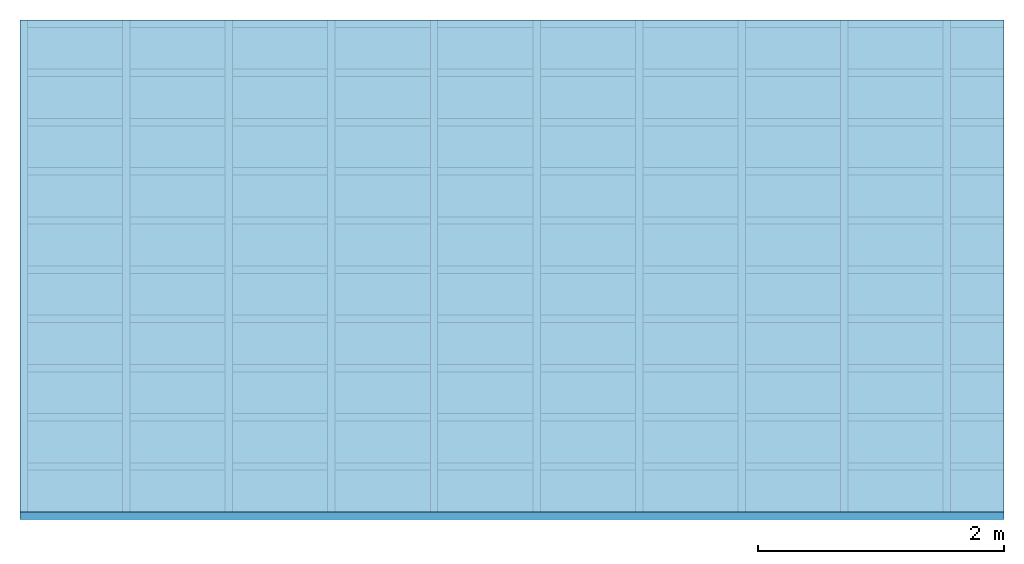
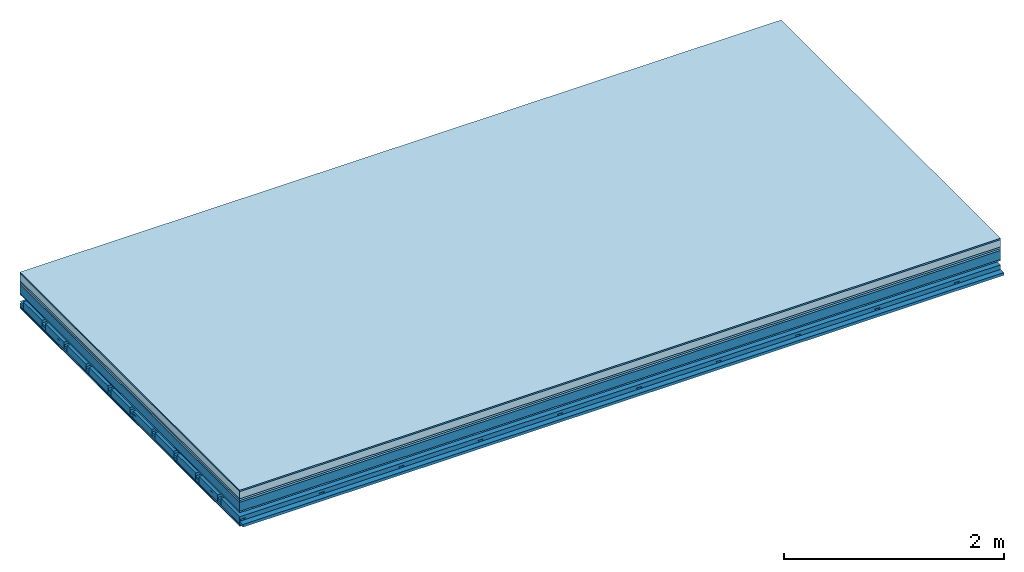
# One storey: 8 plates, 4 members, 1 element without a shape of its own.
"""IFC4 building model written with IfcOpenShell, lengths in metres."""

from ifc_helpers import new_model, si_unit, derived_unit, direction, frame, frame_2d, origin, origin_with_axes, place, context, project, spatial, polyline, rectangle, outline, extrude, material, layer, layer_set, type_object, element, aggregate, save


model = new_model("IFC4")

# Units and contexts
plan_context = context("Plan", 3, precision=1e-05, world=origin(), true_north=direction((0.0, 1.0)))
model_context = context("Model", 3, precision=1e-05, world=origin(), true_north=direction((0.0, 1.0)))
ifc_project = project(units=[si_unit("LENGTHUNIT", "METRE"), derived_unit("SOUNDPRESSUREUNIT", [(si_unit("PRESSUREUNIT", "PASCAL", prefix="MICRO"), 0)]), si_unit("ENERGYUNIT", "JOULE", prefix="MEGA"), si_unit("MASSUNIT", "GRAM", prefix="KILO"), derived_unit("THERMALTRANSMITTANCEUNIT", [(si_unit("POWERUNIT", "WATT"), 1), (si_unit("AREAUNIT", "SQUARE_METRE"), -1), (si_unit("THERMODYNAMICTEMPERATUREUNIT", "KELVIN"), -1)]), derived_unit("AREADENSITYUNIT", [(si_unit("MASSUNIT", "GRAM", prefix="KILO"), 1), (si_unit("AREAUNIT", "SQUARE_METRE"), -1)]), derived_unit("USERDEFINED", [(si_unit("ENERGYUNIT", "JOULE", prefix="MEGA"), 1), (si_unit("AREAUNIT", "SQUARE_METRE"), -1)])], contexts=[plan_context, model_context])

# Site, building, storey
site = spatial("IfcSite", under=ifc_project)
building_placement = place(None, origin())
building = spatial("IfcBuilding", under=site, at=building_placement)
storey_placement = place(building_placement, origin())
storey = spatial("IfcBuildingStorey", under=building, at=storey_placement)

# Slab, members, plates
ifc_material_1 = material(Category="11.013")
ifc_layer_1 = layer(ifc_material_1, 0.015, Name="Flooring")
ifc_material_2 = material(Name="Cement screed", Category="04.006")
ifc_layer_2 = layer(ifc_material_2, 0.08, Name="On-material")
ifc_material_3 = material(Name="Wood fiber generic product", Category="10.009")
ifc_layer_3 = layer(ifc_material_3, 0.02, Name="Impact sound insulation")
ifc_material_4 = material(Category="10.004")
ifc_layer_4 = layer(ifc_material_4, 0.02, Name="Additional insulation")
ifc_material_5 = material(Name="no composite action")
ifc_layer_5 = layer(ifc_material_5, 0.0, Name="Bond")
ifc_layer_6 = layer(None, 0.1, Name="Supporting structure")
ifc_material_6 = material(Name="of the art")
ifc_layer_7 = layer(ifc_material_6, 0.0, Name="Bond")
ifc_material_7 = material(Category="03.007")
ifc_layer_8 = layer(ifc_material_7, 0.015, Name="Lower layer 1")
ifc_layer_9 = layer(None, 0.095, Name="Coupling")
ifc_layer_10 = layer(None, 0.03, Name="Battens / profiles")
ifc_material_8 = material(Name="Plasterboard type A", Category="03.008")
ifc_layer_11 = layer(ifc_material_8, 0.0125, Name="Ceiling covering 1st layer")
ifc_layer_12 = layer(ifc_material_8, 0.0125, Name="Ceiling covering layer 2")
ifc_material_9 = material(Category="04.001")
ifc_layer_13 = layer(ifc_material_9, 0.003, Name="Surface / treatment")
ifc_layer_set = layer_set([ifc_layer_1, ifc_layer_2, ifc_layer_3, ifc_layer_4, ifc_layer_5, ifc_layer_6, ifc_layer_7, ifc_layer_8, ifc_layer_9, ifc_layer_10, ifc_layer_11, ifc_layer_12, ifc_layer_13])
slab_type = type_object("IfcSlabType", Name="A2158", PredefinedType="NOTDEFINED", material=ifc_layer_set)
slab_placement = place(None, frame((0.0, 0.0, 0.0), z_axis=(0.0, 0.0, -1.0), x_axis=(1.0, 0.0, 0.0)))
slab = element("IfcSlab", 1, at=slab_placement, inside=storey, type_object=slab_type, material=ifc_layer_set, Name="Slab #1")
ifc_material_10 = material(Name="Solid timber panel")
member_1_placement = place(slab_placement, origin())
member_1 = element("IfcMember", 2, at=member_1_placement, material=ifc_material_10, Name="Supporting structure", context=plan_context, shape_type="SweptSolid", body=[
    extrude(rectangle(XDim=1.0, YDim=0.1, at=frame_2d((0.5, 0.05), x_axis=(1.0, 0.0))), frame((0.0, 4.0, 0.135), z_axis=(0.0, -1.0, 0.0), x_axis=(1.0, 0.0, 0.0)), (0.0, 0.0, 1.0), 4.0),
    extrude(rectangle(XDim=1.0, YDim=0.1, at=frame_2d((0.5, 0.05), x_axis=(1.0, 0.0))), frame((1.0, 4.0, 0.135), z_axis=(0.0, -1.0, 0.0), x_axis=(1.0, 0.0, 0.0)), (0.0, 0.0, 1.0), 4.0),
    extrude(rectangle(XDim=1.0, YDim=0.1, at=frame_2d((0.5, 0.05), x_axis=(1.0, 0.0))), frame((2.0, 4.0, 0.135), z_axis=(0.0, -1.0, 0.0), x_axis=(1.0, 0.0, 0.0)), (0.0, 0.0, 1.0), 4.0),
    extrude(rectangle(XDim=1.0, YDim=0.1, at=frame_2d((0.5, 0.05), x_axis=(1.0, 0.0))), frame((3.0, 4.0, 0.135), z_axis=(0.0, -1.0, 0.0), x_axis=(1.0, 0.0, 0.0)), (0.0, 0.0, 1.0), 4.0),
    extrude(rectangle(XDim=1.0, YDim=0.1, at=frame_2d((0.5, 0.05), x_axis=(1.0, 0.0))), frame((4.0, 4.0, 0.135), z_axis=(0.0, -1.0, 0.0), x_axis=(1.0, 0.0, 0.0)), (0.0, 0.0, 1.0), 4.0),
    extrude(rectangle(XDim=1.0, YDim=0.1, at=frame_2d((0.5, 0.05), x_axis=(1.0, 0.0))), frame((5.0, 4.0, 0.135), z_axis=(0.0, -1.0, 0.0), x_axis=(1.0, 0.0, 0.0)), (0.0, 0.0, 1.0), 4.0),
    extrude(rectangle(XDim=1.0, YDim=0.1, at=frame_2d((0.5, 0.05), x_axis=(1.0, 0.0))), frame((6.0, 4.0, 0.135), z_axis=(0.0, -1.0, 0.0), x_axis=(1.0, 0.0, 0.0)), (0.0, 0.0, 1.0), 4.0),
    extrude(rectangle(XDim=1.0, YDim=0.1, at=frame_2d((0.5, 0.05), x_axis=(1.0, 0.0))), frame((7.0, 4.0, 0.135), z_axis=(0.0, -1.0, 0.0), x_axis=(1.0, 0.0, 0.0)), (0.0, 0.0, 1.0), 4.0),
])
ifc_material_11 = material()
member_2_placement = place(slab_placement, origin())
member_2 = element("IfcMember", 3, at=member_2_placement, material=ifc_material_11, Name="Coupling", context=plan_context, shape_type="SweptSolid", body=[
    extrude(outline(polyline([(0.0, 0.0), (0.06, 0.0), (0.04, 0.02), (0.02, 0.02), (0.0, 0.0)])), frame((0.0, 4.0, 0.325), z_axis=(0.0, -1.0, 0.0), x_axis=(1.0, 0.0, 0.0)), (0.0, 0.0, 1.0), 4.0),
    extrude(outline(polyline([(0.0, 0.0), (0.06, 0.0), (0.04, 0.02), (0.02, 0.02), (0.0, 0.0)])), frame((0.834, 4.0, 0.325), z_axis=(0.0, -1.0, 0.0), x_axis=(1.0, 0.0, 0.0)), (0.0, 0.0, 1.0), 4.0),
    extrude(outline(polyline([(0.0, 0.0), (0.06, 0.0), (0.04, 0.02), (0.02, 0.02), (0.0, 0.0)])), frame((1.668, 4.0, 0.325), z_axis=(0.0, -1.0, 0.0), x_axis=(1.0, 0.0, 0.0)), (0.0, 0.0, 1.0), 4.0),
    extrude(outline(polyline([(0.0, 0.0), (0.06, 0.0), (0.04, 0.02), (0.02, 0.02), (0.0, 0.0)])), frame((2.502, 4.0, 0.325), z_axis=(0.0, -1.0, 0.0), x_axis=(1.0, 0.0, 0.0)), (0.0, 0.0, 1.0), 4.0),
    extrude(outline(polyline([(0.0, 0.0), (0.06, 0.0), (0.04, 0.02), (0.02, 0.02), (0.0, 0.0)])), frame((3.336, 4.0, 0.325), z_axis=(0.0, -1.0, 0.0), x_axis=(1.0, 0.0, 0.0)), (0.0, 0.0, 1.0), 4.0),
    extrude(outline(polyline([(0.0, 0.0), (0.06, 0.0), (0.04, 0.02), (0.02, 0.02), (0.0, 0.0)])), frame((4.17, 4.0, 0.325), z_axis=(0.0, -1.0, 0.0), x_axis=(1.0, 0.0, 0.0)), (0.0, 0.0, 1.0), 4.0),
    extrude(outline(polyline([(0.0, 0.0), (0.06, 0.0), (0.04, 0.02), (0.02, 0.02), (0.0, 0.0)])), frame((5.004, 4.0, 0.325), z_axis=(0.0, -1.0, 0.0), x_axis=(1.0, 0.0, 0.0)), (0.0, 0.0, 1.0), 4.0),
    extrude(outline(polyline([(0.0, 0.0), (0.06, 0.0), (0.04, 0.02), (0.02, 0.02), (0.0, 0.0)])), frame((5.838, 4.0, 0.325), z_axis=(0.0, -1.0, 0.0), x_axis=(1.0, 0.0, 0.0)), (0.0, 0.0, 1.0), 4.0),
    extrude(outline(polyline([(0.0, 0.0), (0.06, 0.0), (0.04, 0.02), (0.02, 0.02), (0.0, 0.0)])), frame((6.672, 4.0, 0.325), z_axis=(0.0, -1.0, 0.0), x_axis=(1.0, 0.0, 0.0)), (0.0, 0.0, 1.0), 4.0),
    extrude(outline(polyline([(0.0, 0.0), (0.06, 0.0), (0.04, 0.02), (0.02, 0.02), (0.0, 0.0)])), frame((7.506, 4.0, 0.325), z_axis=(0.0, -1.0, 0.0), x_axis=(1.0, 0.0, 0.0)), (0.0, 0.0, 1.0), 4.0),
])
member_3_placement = place(slab_placement, origin())
member_3 = element("IfcMember", 4, at=member_3_placement, material=ifc_material_11, Name="Battens / profiles", context=plan_context, shape_type="SweptSolid", body=[
    extrude(rectangle(XDim=0.06, YDim=0.03, at=frame_2d((0.03, 0.015), x_axis=(1.0, 0.0))), frame((0.0, 0.0, 0.345), z_axis=(1.0, 0.0, 0.0), x_axis=(0.0, 1.0, 0.0)), (0.0, 0.0, 1.0), 8.0),
    extrude(rectangle(XDim=0.06, YDim=0.03, at=frame_2d((0.03, 0.015), x_axis=(1.0, 0.0))), frame((0.0, 0.4, 0.345), z_axis=(1.0, 0.0, 0.0), x_axis=(0.0, 1.0, 0.0)), (0.0, 0.0, 1.0), 8.0),
    extrude(rectangle(XDim=0.06, YDim=0.03, at=frame_2d((0.03, 0.015), x_axis=(1.0, 0.0))), frame((0.0, 0.8, 0.345), z_axis=(1.0, 0.0, 0.0), x_axis=(0.0, 1.0, 0.0)), (0.0, 0.0, 1.0), 8.0),
    extrude(rectangle(XDim=0.06, YDim=0.03, at=frame_2d((0.03, 0.015), x_axis=(1.0, 0.0))), frame((0.0, 1.2, 0.345), z_axis=(1.0, 0.0, 0.0), x_axis=(0.0, 1.0, 0.0)), (0.0, 0.0, 1.0), 8.0),
    extrude(rectangle(XDim=0.06, YDim=0.03, at=frame_2d((0.03, 0.015), x_axis=(1.0, 0.0))), frame((0.0, 1.6, 0.345), z_axis=(1.0, 0.0, 0.0), x_axis=(0.0, 1.0, 0.0)), (0.0, 0.0, 1.0), 8.0),
    extrude(rectangle(XDim=0.06, YDim=0.03, at=frame_2d((0.03, 0.015), x_axis=(1.0, 0.0))), frame((0.0, 2.0, 0.345), z_axis=(1.0, 0.0, 0.0), x_axis=(0.0, 1.0, 0.0)), (0.0, 0.0, 1.0), 8.0),
    extrude(rectangle(XDim=0.06, YDim=0.03, at=frame_2d((0.03, 0.015), x_axis=(1.0, 0.0))), frame((0.0, 2.4, 0.345), z_axis=(1.0, 0.0, 0.0), x_axis=(0.0, 1.0, 0.0)), (0.0, 0.0, 1.0), 8.0),
    extrude(rectangle(XDim=0.06, YDim=0.03, at=frame_2d((0.03, 0.015), x_axis=(1.0, 0.0))), frame((0.0, 2.8, 0.345), z_axis=(1.0, 0.0, 0.0), x_axis=(0.0, 1.0, 0.0)), (0.0, 0.0, 1.0), 8.0),
    extrude(rectangle(XDim=0.06, YDim=0.03, at=frame_2d((0.03, 0.015), x_axis=(1.0, 0.0))), frame((0.0, 3.2, 0.345), z_axis=(1.0, 0.0, 0.0), x_axis=(0.0, 1.0, 0.0)), (0.0, 0.0, 1.0), 8.0),
    extrude(rectangle(XDim=0.06, YDim=0.03, at=frame_2d((0.03, 0.015), x_axis=(1.0, 0.0))), frame((0.0, 3.6, 0.345), z_axis=(1.0, 0.0, 0.0), x_axis=(0.0, 1.0, 0.0)), (0.0, 0.0, 1.0), 8.0),
    extrude(rectangle(XDim=0.06, YDim=0.03, at=frame_2d((0.03, 0.015), x_axis=(1.0, 0.0))), frame((0.0, 4.0, 0.345), z_axis=(1.0, 0.0, 0.0), x_axis=(0.0, 1.0, 0.0)), (0.0, 0.0, 1.0), 8.0),
])
ifc_material_12 = material()
member_4_placement = place(slab_placement, origin())
member_4 = element("IfcMember", 5, at=member_4_placement, material=ifc_material_12, Name="Cavity", context=plan_context, shape_type="SweptSolid", body=[
    extrude(rectangle(XDim=0.34, YDim=0.08, at=frame_2d((0.17, 0.04), x_axis=(1.0, 0.0))), frame((0.0, 0.06, 0.295), z_axis=(1.0, 0.0, 0.0), x_axis=(0.0, 1.0, 0.0)), (0.0, 0.0, 1.0), 8.0),
    extrude(rectangle(XDim=0.34, YDim=0.08, at=frame_2d((0.17, 0.04), x_axis=(1.0, 0.0))), frame((0.0, 0.46, 0.295), z_axis=(1.0, 0.0, 0.0), x_axis=(0.0, 1.0, 0.0)), (0.0, 0.0, 1.0), 8.0),
    extrude(rectangle(XDim=0.34, YDim=0.08, at=frame_2d((0.17, 0.04), x_axis=(1.0, 0.0))), frame((0.0, 0.86, 0.295), z_axis=(1.0, 0.0, 0.0), x_axis=(0.0, 1.0, 0.0)), (0.0, 0.0, 1.0), 8.0),
    extrude(rectangle(XDim=0.34, YDim=0.08, at=frame_2d((0.17, 0.04), x_axis=(1.0, 0.0))), frame((0.0, 1.26, 0.295), z_axis=(1.0, 0.0, 0.0), x_axis=(0.0, 1.0, 0.0)), (0.0, 0.0, 1.0), 8.0),
    extrude(rectangle(XDim=0.34, YDim=0.08, at=frame_2d((0.17, 0.04), x_axis=(1.0, 0.0))), frame((0.0, 1.66, 0.295), z_axis=(1.0, 0.0, 0.0), x_axis=(0.0, 1.0, 0.0)), (0.0, 0.0, 1.0), 8.0),
    extrude(rectangle(XDim=0.34, YDim=0.08, at=frame_2d((0.17, 0.04), x_axis=(1.0, 0.0))), frame((0.0, 2.06, 0.295), z_axis=(1.0, 0.0, 0.0), x_axis=(0.0, 1.0, 0.0)), (0.0, 0.0, 1.0), 8.0),
    extrude(rectangle(XDim=0.34, YDim=0.08, at=frame_2d((0.17, 0.04), x_axis=(1.0, 0.0))), frame((0.0, 2.46, 0.295), z_axis=(1.0, 0.0, 0.0), x_axis=(0.0, 1.0, 0.0)), (0.0, 0.0, 1.0), 8.0),
    extrude(rectangle(XDim=0.34, YDim=0.08, at=frame_2d((0.17, 0.04), x_axis=(1.0, 0.0))), frame((0.0, 2.86, 0.295), z_axis=(1.0, 0.0, 0.0), x_axis=(0.0, 1.0, 0.0)), (0.0, 0.0, 1.0), 8.0),
    extrude(rectangle(XDim=0.34, YDim=0.08, at=frame_2d((0.17, 0.04), x_axis=(1.0, 0.0))), frame((0.0, 3.26, 0.295), z_axis=(1.0, 0.0, 0.0), x_axis=(0.0, 1.0, 0.0)), (0.0, 0.0, 1.0), 8.0),
    extrude(rectangle(XDim=0.34, YDim=0.08, at=frame_2d((0.17, 0.04), x_axis=(1.0, 0.0))), frame((0.0, 3.66, 0.295), z_axis=(1.0, 0.0, 0.0), x_axis=(0.0, 1.0, 0.0)), (0.0, 0.0, 1.0), 8.0),
])
plate_1_placement = place(slab_placement, origin())
plate_1 = element("IfcPlate", 6, at=plate_1_placement, material=ifc_material_1, Name="Flooring", context=plan_context, shape_type="SweptSolid", body=[
    extrude(rectangle(XDim=8.0, YDim=4.0, at=frame_2d((4.0, 2.0), x_axis=(1.0, 0.0))), origin_with_axes(), (0.0, 0.0, 1.0), 0.015),
])
plate_2_placement = place(slab_placement, origin())
plate_2 = element("IfcPlate", 7, at=plate_2_placement, material=ifc_material_2, Name="On-material", context=plan_context, shape_type="SweptSolid", body=[
    extrude(rectangle(XDim=8.0, YDim=4.0, at=frame_2d((4.0, 2.0), x_axis=(1.0, 0.0))), frame((0.0, 0.0, 0.015), z_axis=(0.0, 0.0, 1.0), x_axis=(1.0, 0.0, 0.0)), (0.0, 0.0, 1.0), 0.08),
])
plate_3_placement = place(slab_placement, origin())
plate_3 = element("IfcPlate", 8, at=plate_3_placement, material=ifc_material_3, Name="Impact sound insulation", context=plan_context, shape_type="SweptSolid", body=[
    extrude(rectangle(XDim=8.0, YDim=4.0, at=frame_2d((4.0, 2.0), x_axis=(1.0, 0.0))), frame((0.0, 0.0, 0.095), z_axis=(0.0, 0.0, 1.0), x_axis=(1.0, 0.0, 0.0)), (0.0, 0.0, 1.0), 0.02),
])
plate_4_placement = place(slab_placement, origin())
plate_4 = element("IfcPlate", 9, at=plate_4_placement, material=ifc_material_4, Name="Additional insulation", context=plan_context, shape_type="SweptSolid", body=[
    extrude(rectangle(XDim=8.0, YDim=4.0, at=frame_2d((4.0, 2.0), x_axis=(1.0, 0.0))), frame((0.0, 0.0, 0.115), z_axis=(0.0, 0.0, 1.0), x_axis=(1.0, 0.0, 0.0)), (0.0, 0.0, 1.0), 0.02),
])
plate_5_placement = place(slab_placement, origin())
plate_5 = element("IfcPlate", 10, at=plate_5_placement, material=ifc_material_7, Name="Lower layer 1", context=plan_context, shape_type="SweptSolid", body=[
    extrude(rectangle(XDim=8.0, YDim=4.0, at=frame_2d((4.0, 2.0), x_axis=(1.0, 0.0))), frame((0.0, 0.0, 0.235), z_axis=(0.0, 0.0, 1.0), x_axis=(1.0, 0.0, 0.0)), (0.0, 0.0, 1.0), 0.015),
])
plate_6_placement = place(slab_placement, origin())
plate_6 = element("IfcPlate", 11, at=plate_6_placement, material=ifc_material_8, Name="Ceiling covering 1st layer", context=plan_context, shape_type="SweptSolid", body=[
    extrude(rectangle(XDim=8.0, YDim=4.0, at=frame_2d((4.0, 2.0), x_axis=(1.0, 0.0))), frame((0.0, 0.0, 0.375), z_axis=(0.0, 0.0, 1.0), x_axis=(1.0, 0.0, 0.0)), (0.0, 0.0, 1.0), 0.0125),
])
plate_7_placement = place(slab_placement, origin())
plate_7 = element("IfcPlate", 12, at=plate_7_placement, material=ifc_material_8, Name="Ceiling covering layer 2", context=plan_context, shape_type="SweptSolid", body=[
    extrude(rectangle(XDim=8.0, YDim=4.0, at=frame_2d((4.0, 2.0), x_axis=(1.0, 0.0))), frame((0.0, 0.0, 0.3875), z_axis=(0.0, 0.0, 1.0), x_axis=(1.0, 0.0, 0.0)), (0.0, 0.0, 1.0), 0.0125),
])
plate_8_placement = place(slab_placement, origin())
plate_8 = element("IfcPlate", 13, at=plate_8_placement, material=ifc_material_9, Name="Surface / treatment", context=plan_context, shape_type="SweptSolid", body=[
    extrude(rectangle(XDim=8.0, YDim=4.0, at=frame_2d((4.0, 2.0), x_axis=(1.0, 0.0))), frame((0.0, 0.0, 0.4), z_axis=(0.0, 0.0, 1.0), x_axis=(1.0, 0.0, 0.0)), (0.0, 0.0, 1.0), 0.003),
])
aggregate(slab, [plate_1, plate_2, plate_3, plate_4, member_1, plate_5, member_2, member_3, member_4, plate_6, plate_7, plate_8])

save(model, "model.ifc")
